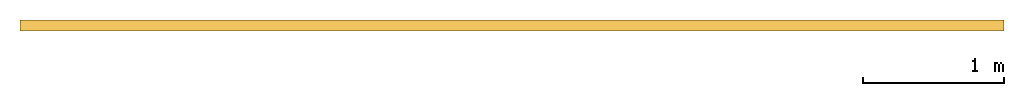
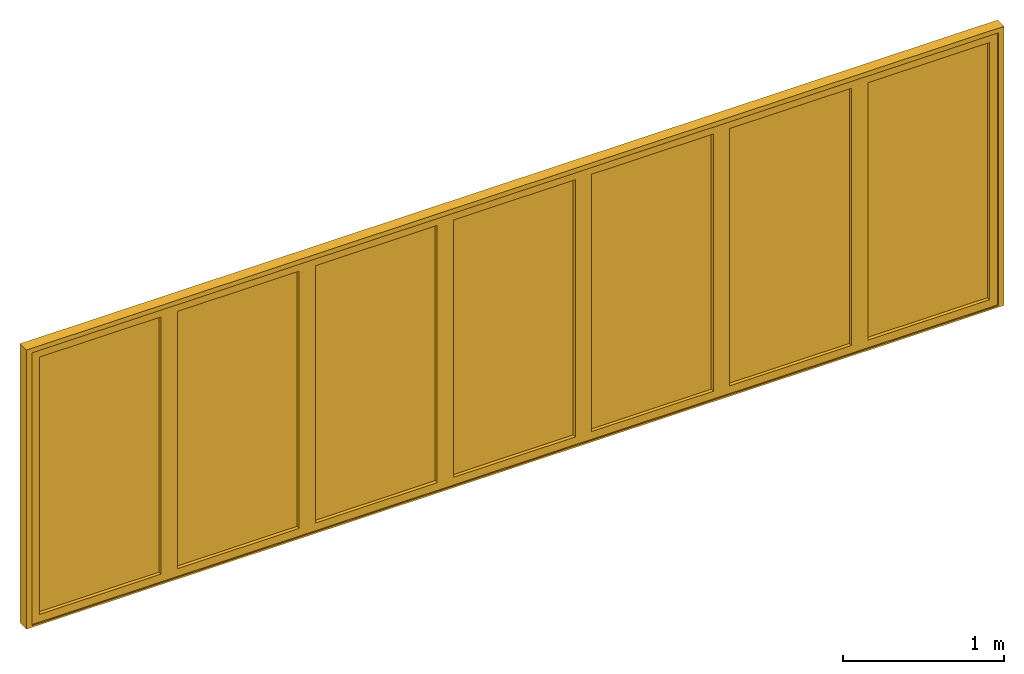
# One storey: 1 door.
"""IFC2X3 building model written with IfcOpenShell, lengths in millimetres."""

from ifc_helpers import new_model, entity, si_unit, converted_unit, direction, frame, frame_2d, origin, place, context, subcontext, project, spatial, polyline, rectangle, outline, extrude, source, transform, mapped, material, material_list, type_object, type_shapes, element, save


model = new_model("IFC2X3")

# Units and contexts
model_context = context("Model", 3, precision=1e-06, world=origin(), true_north=direction((2.0, -1.71512652170913e-15, 1.0)))
context_of_model = context(None, 3, precision=1e-06, world=origin(), true_north=direction((2.0, -1.71512652170913e-15, 1.0)))
body_context = subcontext(model_context, "Body", "Model", "MODEL_VIEW")
ifc_project = project(units=[si_unit("LENGTHUNIT", "METRE", prefix="MILLI"), si_unit("AREAUNIT", "SQUARE_METRE", prefix="MILLI"), si_unit("VOLUMEUNIT", "CUBIC_METRE", prefix="MILLI"), converted_unit("PLANEANGLEUNIT", "DEGREE", entity("IfcRatioMeasure", 0.0174532925199433), si_unit("PLANEANGLEUNIT", "RADIAN"), dimensions=[0, 0, 0, 0, 0, 0, 0]), si_unit("TIMEUNIT", "SECOND")], contexts=[model_context, context_of_model])

# Site, building, storey
site_placement = place(None, origin())
site = spatial("IfcSite", under=ifc_project, at=site_placement, CompositionType="ELEMENT")
building_placement = place(site_placement, origin())
building = spatial("IfcBuilding", under=site, at=building_placement, CompositionType="ELEMENT")
storey_placement = place(building_placement, origin())
storey = spatial("IfcBuildingStorey", under=building, at=storey_placement, Name="Ground Floor", CompositionType="ELEMENT", Elevation=0.0)

# Door
ifc_material_1 = material(Name="Glass-Blue")
ifc_material_2 = material(Name="Mtl-Aluminium")
ifc_material_list = material_list([ifc_material_1, ifc_material_2])
door_style = type_object("IfcDoorStyle", ConstructionType="NOTDEFINED", OperationType="NOTDEFINED", ParameterTakesPrecedence=False, Sizeable=False)
shared_shape = source(origin(), body_context, "Body", "SweptSolid", [
    extrude(rectangle(XDim=871.114300000001, YDim=18.0, at=frame_2d((0.0, -1.68753899743024e-14), x_axis=(1.0, 0.0))), frame((6915.85765, 265.05, 58.7), z_axis=(0.0, 0.0, 1.0), x_axis=(-1.0, 0.0, 0.0)), (0.0, 0.0, 1.0), 1947.7),
    extrude(outline(polyline([(-494.25715, -1032.55), (494.25715, -1032.55), (494.25715, 1032.55), (-494.25715, 1032.55), (-494.25715, -1032.55)]), holes=[polyline([(435.55715, 973.85), (435.55715, -973.85), (-435.55715, -973.85), (-435.55715, 973.85), (435.55715, 973.85)])]), frame((6915.85765, 230.1, 1032.55), z_axis=(0.0, 1.0, 0.0), x_axis=(-1.0, 0.0, 0.0)), (0.0, 0.0, 1.0), 69.9),
    extrude(rectangle(XDim=871.114299999998, YDim=18.0, at=frame_2d((0.0, -1.68753899743024e-14), x_axis=(1.0, 0.0))), frame((5927.34335, 265.05, 58.7), z_axis=(0.0, 0.0, 1.0), x_axis=(-1.0, 0.0, 0.0)), (0.0, 0.0, 1.0), 1947.7),
    extrude(outline(polyline([(-494.25715, -1032.55), (494.25715, -1032.55), (494.25715, 1032.55), (-494.25715, 1032.55), (-494.25715, -1032.55)]), holes=[polyline([(435.557149999999, 973.85), (435.557149999999, -973.85), (-435.557149999999, -973.85), (-435.557149999999, 973.85), (435.557149999999, 973.85)])]), frame((5927.34335, 230.1, 1032.55), z_axis=(0.0, 1.0, 0.0), x_axis=(-1.0, 0.0, 0.0)), (0.0, 0.0, 1.0), 69.9),
    extrude(rectangle(XDim=871.114259999999, YDim=18.0, at=frame_2d((-5.40012479177676e-13, -1.68753899743024e-14), x_axis=(1.0, 0.0))), frame((4938.82907, 265.05, 58.7), z_axis=(0.0, 0.0, 1.0), x_axis=(-1.0, 0.0, 0.0)), (0.0, 0.0, 1.0), 1947.7),
    extrude(outline(polyline([(-494.257130000001, -1032.55), (494.25713, -1032.55), (494.25713, 1032.55), (-494.257130000001, 1032.55), (-494.257130000001, -1032.55)]), holes=[polyline([(435.557129999999, 973.85), (435.557129999999, -973.85), (-435.55713, -973.85), (-435.55713, 973.85), (435.557129999999, 973.85)])]), frame((4938.82907, 230.1, 1032.55), z_axis=(0.0, 1.0, 0.0), x_axis=(-1.0, 0.0, 0.0)), (0.0, 0.0, 1.0), 69.9),
    extrude(rectangle(XDim=871.11428, YDim=18.0, at=frame_2d((0.0, -1.68753899743024e-14), x_axis=(1.0, 0.0))), frame((3950.3148, 265.05, 58.7), z_axis=(0.0, 0.0, 1.0), x_axis=(-1.0, 0.0, 0.0)), (0.0, 0.0, 1.0), 1947.7),
    extrude(outline(polyline([(-494.25714, -1032.55), (494.25714, -1032.55), (494.25714, 1032.55), (-494.25714, 1032.55), (-494.25714, -1032.55)]), holes=[polyline([(435.55714, 973.85), (435.55714, -973.85), (-435.557140000001, -973.85), (-435.557140000001, 973.85), (435.55714, 973.85)])]), frame((3950.3148, 230.1, 1032.55), z_axis=(0.0, 1.0, 0.0), x_axis=(-1.0, 0.0, 0.0)), (0.0, 0.0, 1.0), 69.9),
    extrude(rectangle(XDim=871.11426, YDim=18.0, at=frame_2d((0.0, -1.68753899743024e-14), x_axis=(1.0, 0.0))), frame((2961.80053, 265.05, 58.7), z_axis=(0.0, 0.0, 1.0), x_axis=(-1.0, 0.0, 0.0)), (0.0, 0.0, 1.0), 1947.7),
    extrude(outline(polyline([(-494.25713, -1032.55), (494.25713, -1032.55), (494.25713, 1032.55), (-494.25713, 1032.55), (-494.25713, -1032.55)]), holes=[polyline([(435.557129999999, 973.85), (435.557129999999, -973.85), (-435.557130000001, -973.85), (-435.557130000001, 973.85), (435.557129999999, 973.85)])]), frame((2961.80053, 230.1, 1032.55), z_axis=(0.0, 1.0, 0.0), x_axis=(-1.0, 0.0, 0.0)), (0.0, 0.0, 1.0), 69.9),
    extrude(rectangle(XDim=871.1143, YDim=18.0, at=frame_2d((-1.4210854715202e-13, -1.68753899743024e-14), x_axis=(1.0, 0.0))), frame((1973.28625, 265.05, 58.7), z_axis=(0.0, 0.0, 1.0), x_axis=(-1.0, 0.0, 0.0)), (0.0, 0.0, 1.0), 1947.7),
    extrude(outline(polyline([(-494.25715, -1032.55), (494.25715, -1032.55), (494.25715, 1032.55), (-494.25715, 1032.55), (-494.25715, -1032.55)]), holes=[polyline([(435.55715, 973.85), (435.55715, -973.85), (-435.55715, -973.85), (-435.55715, 973.85), (435.55715, 973.85)])]), frame((1973.28625, 230.1, 1032.55), z_axis=(0.0, 1.0, 0.0), x_axis=(-1.0, 0.0, 0.0)), (0.0, 0.0, 1.0), 69.9),
    extrude(rectangle(XDim=871.1143, YDim=18.0, at=frame_2d((0.0, -1.68753899743024e-14), x_axis=(1.0, 0.0))), frame((984.77195, 265.05, 58.7), z_axis=(0.0, 0.0, 1.0), x_axis=(-1.0, 0.0, 0.0)), (0.0, 0.0, 1.0), 1947.7),
    extrude(outline(polyline([(-494.25715, -1032.55), (494.25715, -1032.55), (494.25715, 1032.55), (-494.25715, 1032.55), (-494.25715, -1032.55)]), holes=[polyline([(435.55715, 973.85), (435.55715, -973.85), (-435.55715, -973.85), (-435.55715, 973.85), (435.55715, 973.85)])]), frame((984.77195, 230.1, 1032.55), z_axis=(0.0, 1.0, 0.0), x_axis=(-1.0, 0.0, 0.0)), (0.0, 0.0, 1.0), 69.9),
    extrude(rectangle(XDim=40.1999999999999, YDim=79.4, at=frame_2d((-3.37507799486048e-14, -3.5527136788005e-14), x_axis=(1.0, 0.0))), frame((470.4148, 260.3, 0.0), z_axis=(0.0, 0.0, 1.0), x_axis=(-1.0, 0.0, 0.0)), (0.0, 0.0, 1.0), 2065.1),
    extrude(rectangle(XDim=40.1999999999995, YDim=79.4, at=frame_2d((0.0, -3.5527136788005e-14), x_axis=(1.0, 0.0))), frame((7430.2148, 260.3, 0.0), z_axis=(0.0, 0.0, 1.0), x_axis=(-1.0, 0.0, 0.0)), (0.0, 0.0, 1.0), 2065.1),
    extrude(rectangle(XDim=7000.0, YDim=79.4, at=frame_2d((0.0, -3.5527136788005e-14), x_axis=(1.0, 0.0))), frame((3950.3148, 260.3, 2065.1), z_axis=(0.0, 0.0, 1.0), x_axis=(-1.0, 0.0, 0.0)), (0.0, 0.0, 1.0), 34.9000000000002),
    extrude(rectangle(XDim=7000.0, YDim=79.4, at=frame_2d((0.0, -3.5527136788005e-14), x_axis=(1.0, 0.0))), frame((3950.3148, 260.3, -12.9), z_axis=(0.0, 0.0, 1.0), x_axis=(-1.0, 0.0, 0.0)), (0.0, 0.0, 1.0), 12.9),
])
type_shapes(door_style, [shared_shape])
door_placement = place(storey_placement, origin())
element("IfcDoor", 1, at=door_placement, inside=storey, type_object=door_style, material=ifc_material_list, OverallHeight=2112.9, OverallWidth=7000.0, context=body_context, shape_type="MappedRepresentation", body=[
    mapped(shared_shape, transform((0.0, 0.0, 0.0), scale=1.0)),
])

save(model, "model.ifc")
